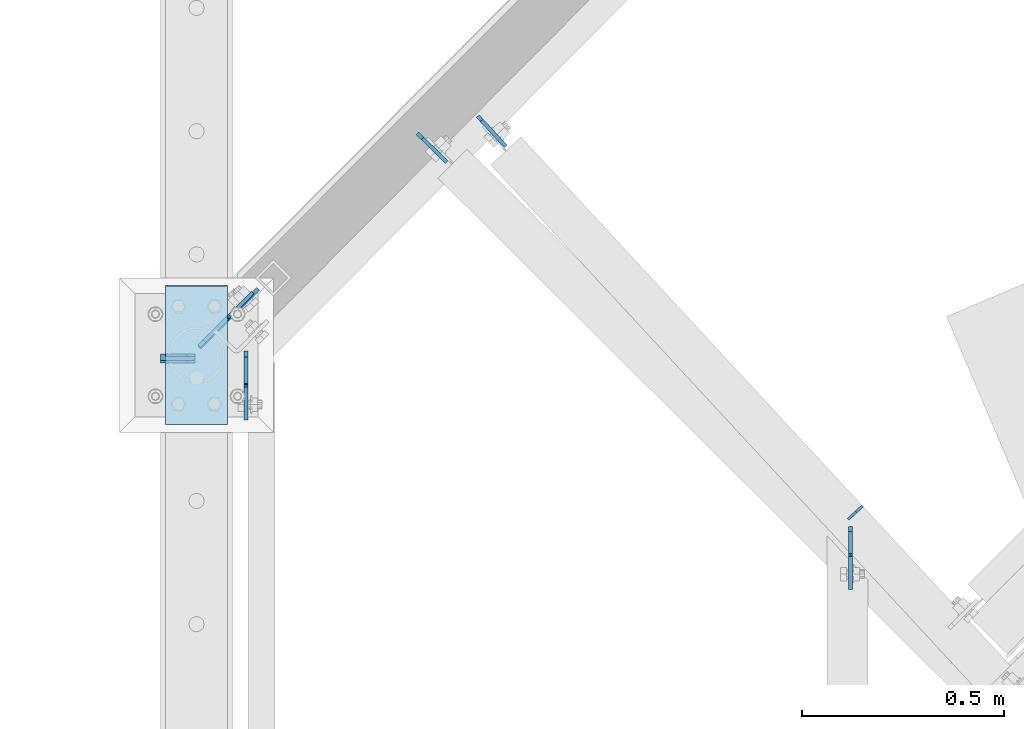
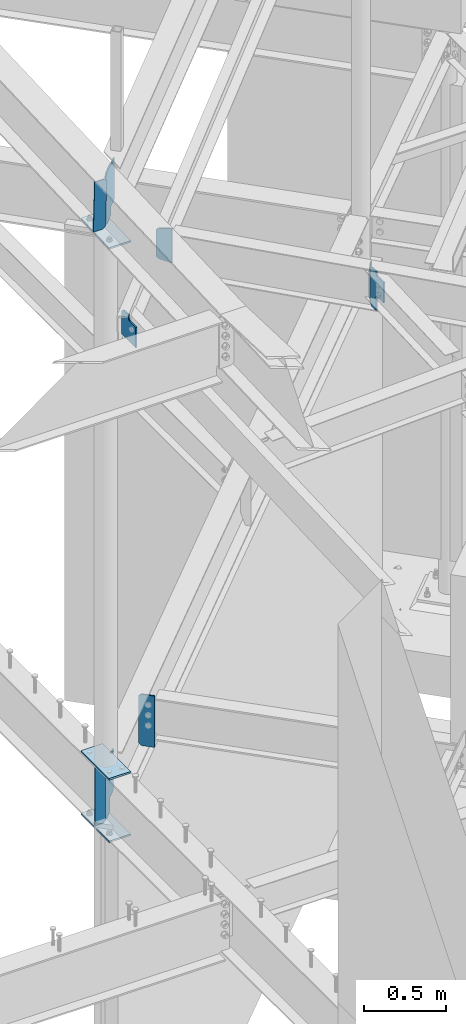
# One storey, part 915 of 975: 12 plates.
"""IFC2X3 building model written with IfcOpenShell, lengths in millimetres."""

import ifcopenshell
import ifcopenshell.guid

model = None  # the IFC model being written
_history = None  # IfcOwnerHistory: only IFC2X3 demands one
_inside = {}  # id of a spatial element -> (the spatial element, [elements in it])
_under = {}  # id of a project, library or spatial element -> (it, [spatial elements below it])
_declared = {}  # id of a project -> (the project, [libraries it declares])
_typed = {}  # id of a type object -> (the type object, [elements of that type])
_made_of = {}  # id of a material, layer set ... -> (it, [elements and type objects made of it])


def new_model(schema):
    """Start an empty IFC model of exactly this schema.

    Asked for "IFC4X3", IfcOpenShell would pick the latest addendum, in which some entities
    have other attributes; the version numbers below select the first issue.
    IFC2X3 requires an IfcOwnerHistory on every rooted entity: one is made here for all.
    """
    global model, _history
    if schema == "IFC4X3":
        model = ifcopenshell.file(schema_version=(4, 3, 0, 0))
    else:
        model = ifcopenshell.file(schema=schema)
    _inside.clear()
    _under.clear()
    _declared.clear()
    _typed.clear()
    _made_of.clear()
    _history = None
    if model.schema == "IFC2X3":
        org = make("IfcOrganization", Name="unknown")
        user = make(
            "IfcPersonAndOrganization",
            ThePerson=make("IfcPerson", FamilyName="unknown"),
            TheOrganization=org,
        )
        app = make(
            "IfcApplication",
            ApplicationDeveloper=org,
            Version="unknown",
            ApplicationFullName="unknown",
            ApplicationIdentifier="unknown",
        )
        _history = make(
            "IfcOwnerHistory",
            OwningUser=user,
            OwningApplication=app,
            ChangeAction="ADDED",
            CreationDate=0,
        )
    return model


def make(cls, **values):
    """One entity of the class cls with the attributes given. An attribute that is None is left unset."""
    return model.create_entity(
        cls, **{name: value for name, value in values.items() if value is not None}
    )


def rooted(cls, **values):
    """An entity with a GlobalId (a new one), such as an element, a storey or a relation."""
    return make(cls, GlobalId=ifcopenshell.guid.new(), OwnerHistory=_history, **values)


def si_unit(unit_type, name, prefix=None):
    """IfcSIUnit, for example si_unit("LENGTHUNIT", "METRE", prefix="MILLI")."""
    return make("IfcSIUnit", UnitType=unit_type, Prefix=prefix, Name=name)


def assignment(units):
    """IfcUnitAssignment: the units of a project."""
    return None if units is None else make("IfcUnitAssignment", Units=units)


def point(xyz):
    """IfcCartesianPoint."""
    return None if xyz is None else make("IfcCartesianPoint", Coordinates=xyz)


def direction(xyz):
    """IfcDirection."""
    return None if xyz is None else make("IfcDirection", DirectionRatios=xyz)


def frame(location, z_axis=None, x_axis=None):
    """IfcAxis2Placement3D, a coordinate frame: its origin and axes. An axis left out is left unset."""
    return make(
        "IfcAxis2Placement3D",
        Location=point(location),
        Axis=direction(z_axis),
        RefDirection=direction(x_axis),
    )


def origin_with_axes():
    """The frame at (0, 0, 0) with the z axis (0, 0, 1) and the x axis (1, 0, 0) written out."""
    return frame((0.0, 0.0, 0.0), z_axis=(0.0, 0.0, 1.0), x_axis=(1.0, 0.0, 0.0))


def place(relative_to, where):
    """IfcLocalPlacement: puts the frame where relative to a parent placement (None: the world)."""
    return make(
        "IfcLocalPlacement", PlacementRelTo=relative_to, RelativePlacement=where
    )


def context(
    kind, dimensions, precision=None, world=None, true_north=None, identifier=None
):
    """IfcGeometricRepresentationContext, for example the 3D "Model" context."""
    return make(
        "IfcGeometricRepresentationContext",
        ContextIdentifier=identifier,
        ContextType=kind,
        CoordinateSpaceDimension=dimensions,
        Precision=precision,
        WorldCoordinateSystem=world,
        TrueNorth=true_north,
    )


def subcontext(parent, identifier, kind, view, scale=None):
    """IfcGeometricRepresentationSubContext, for example "Body" below "Model"."""
    return make(
        "IfcGeometricRepresentationSubContext",
        ContextIdentifier=identifier,
        ContextType=kind,
        ParentContext=parent,
        TargetScale=scale,
        TargetView=view,
    )


def project(units=None, contexts=None):
    """IfcProject with its units and contexts."""
    return rooted(
        "IfcProject",
        Name="project",
        RepresentationContexts=contexts,
        UnitsInContext=assignment(units),
    )


def spatial(cls, under=None, at=None, **own):
    """A site, building, storey or space (cls), placed at a placement, below another one or the project."""
    s = rooted(cls, ObjectPlacement=at, **own)
    if under is not None:
        _under.setdefault(under.id(), (under, []))[1].append(s)
    return s


def faces_of(points, faces, orient=None, outer=None):
    """IfcFace entities. A face is a list of loops; a loop is a list of indices into points, from 0.

    orient and outer hold one flag for each loop. By default every Orientation is true, the
    first loop of a face is its IfcFaceOuterBound and the others are IfcFaceBound.
    """
    made = []
    for i, loops in enumerate(faces):
        bounds = []
        for j, loop in enumerate(loops):
            is_outer = j == 0 if outer is None else outer[i][j]
            bounds.append(
                make(
                    "IfcFaceOuterBound" if is_outer else "IfcFaceBound",
                    Bound=make("IfcPolyLoop", Polygon=[points[k] for k in loop]),
                    Orientation=True if orient is None else orient[i][j],
                )
            )
        made.append(make("IfcFace", Bounds=bounds))
    return made


def faceted_brep(points, faces, orient=None, outer=None, voids=None):
    """IfcFacetedBrep: a solid bounded by flat faces; with voids (closed shells), ...WithVoids."""
    shared = [point(p) for p in points]
    hull = make("IfcClosedShell", CfsFaces=faces_of(shared, faces, orient, outer))
    if voids is None:
        return make("IfcFacetedBrep", Outer=hull)
    return make(
        "IfcFacetedBrepWithVoids",
        Outer=hull,
        Voids=[
            make(cls, CfsFaces=faces_of(shared, fs, o, b)) for cls, fs, o, b in voids
        ],
    )


def shape(context_of_items, identifier, shape_type, items):
    """IfcShapeRepresentation: the items that make up one representation, for example the "Body"."""
    return make(
        "IfcShapeRepresentation",
        ContextOfItems=context_of_items,
        RepresentationIdentifier=identifier,
        RepresentationType=shape_type,
        Items=items,
    )


def material(Name=None, Category=None):
    """IfcMaterial."""
    return make("IfcMaterial", Name=Name, Category=Category)


def made_of(thing, what):
    """Note that an element or type object is made of a material, layer set ...; save() writes the relation."""
    if what is not None:
        _made_of.setdefault(what.id(), (what, []))[1].append(thing)
    return thing


def type_object(cls, material=None, **own):
    """A type object (cls), such as IfcWallType, which elements share."""
    return made_of(rooted(cls, **own), material)


def element(
    cls,
    number,
    at=None,
    inside=None,
    cuts=None,
    type_object=None,
    material=None,
    context=None,
    identifier="Body",
    shape_type=None,
    held_by="IfcProductDefinitionShape",
    body=None,
    shapes=None,
    **own,
):
    """One element of the class cls, such as IfcWall. Its Tag is "e" and its number.

    at: its placement. inside: the storey or other place that contains it. cuts: it is an
    opening in that element (IfcRelVoidsElement). A single representation is given by context,
    identifier, shape_type and body (its items); several are given by shapes. held_by: the class
    of the entity that holds the representations. save() writes the other relations.
    """
    e = rooted(cls, Tag="e%d" % number, ObjectPlacement=at, **own)
    if body is not None:
        shapes = [shape(context, identifier, shape_type, body)]
    if shapes is not None:
        e.Representation = make(held_by, Representations=shapes)
    if inside is not None:
        _inside.setdefault(inside.id(), (inside, []))[1].append(e)
    if cuts is not None:
        rooted(
            "IfcRelVoidsElement", RelatingBuildingElement=cuts, RelatedOpeningElement=e
        )
    if type_object is not None:
        _typed.setdefault(type_object.id(), (type_object, []))[1].append(e)
    return made_of(e, material)


def aggregate(whole, parts):
    """IfcRelAggregates: a whole, such as a stair, and the parts it consists of."""
    return rooted("IfcRelAggregates", RelatingObject=whole, RelatedObjects=parts)


def save(model, path):
    """Write the relations noted so far, then the file.

    IfcRelAggregates (storeys below a building ...), IfcRelContainedInSpatialStructure (elements
    in a storey), IfcRelDefinesByType, IfcRelAssociatesMaterial and IfcRelDeclares: one each for
    every whole, place, type object, material and project.
    """
    for whole, parts in _under.values():
        aggregate(whole, parts)
    for where, things in _inside.values():
        rooted(
            "IfcRelContainedInSpatialStructure",
            RelatedElements=things,
            RelatingStructure=where,
        )
    for kind, things in _typed.values():
        rooted("IfcRelDefinesByType", RelatedObjects=things, RelatingType=kind)
    for what, things in _made_of.values():
        rooted("IfcRelAssociatesMaterial", RelatedObjects=things, RelatingMaterial=what)
    for by, libraries in _declared.values():
        rooted("IfcRelDeclares", RelatingContext=by, RelatedDefinitions=libraries)
    model.write(path)


model = new_model("IFC2X3")

# Units and contexts
model_context = context("Model", 3, precision=1e-05, world=origin_with_axes())
body_context = subcontext(model_context, "Body", "Model", "MODEL_VIEW")
ifc_project = project(units=[si_unit("LENGTHUNIT", "METRE", prefix="MILLI"), si_unit("AREAUNIT", "SQUARE_METRE"), si_unit("VOLUMEUNIT", "CUBIC_METRE"), si_unit("MASSUNIT", "GRAM", prefix="KILO"), si_unit("TIMEUNIT", "SECOND"), si_unit("PLANEANGLEUNIT", "RADIAN"), si_unit("SOLIDANGLEUNIT", "STERADIAN"), si_unit("THERMODYNAMICTEMPERATUREUNIT", "DEGREE_CELSIUS"), si_unit("LUMINOUSINTENSITYUNIT", "LUMEN")], contexts=[model_context])

# Site, building, storey
site_placement = place(None, origin_with_axes())
site = spatial("IfcSite", under=ifc_project, at=site_placement, CompositionType="ELEMENT")
building_placement = place(site_placement, origin_with_axes())
building = spatial("IfcBuilding", under=site, at=building_placement, Name="Undefined", CompositionType="ELEMENT")
storey_placement = place(building_placement, origin_with_axes())
storey = spatial("IfcBuildingStorey", under=building, at=storey_placement, Name="Undefined", CompositionType="ELEMENT", Elevation=0.0)

# Plates
ifc_material = material(Name="STEEL/A36")
plate_type_1 = type_object("IfcPlateType", PredefinedType="NOTDEFINED")
plate_1_placement = place(storey_placement, frame((29839.6453487716, 7390.2823653138, 3514.725), z_axis=(0.498659746960537, 0.501336669960325, 0.707106781267402), x_axis=(0.498659747074602, 0.501336670074949, -0.707106781105694)))
element("IfcPlate", 1, at=plate_1_placement, inside=storey, type_object=plate_type_1, material=ifc_material, Name="PLATE", context=body_context, shape_type="Brep", body=[
    faceted_brep([(0.0, -4.76250000000073, 0.0), (-278.387939453176, -4.76250000000073, 278.387939453169), (-278.387939453176, 4.76250000000073, 278.387939453169), (0.0, 4.76250000000073, 0.0), (-278.38793945321, -4.76250000000073, 303.083648681655), (-278.38793945321, 4.76250000000073, 303.083648681655), (-221.696075439293, -4.76250000028085, 359.775512695589), (-221.696075439297, 4.76249999971878, 359.775512695589), (-211.593292011852, -4.76250000026994, 349.672729268135), (-211.593292011856, 4.76249999972788, 349.672729268135), (-207.473115897639, -4.7625000002663, 346.919715514257), (-207.473115897639, 4.76249999973152, 346.919715514257), (-202.613036791854, -4.7625000002663, 345.952985445063), (-202.613036791854, 4.76249999973334, 345.952985445063), (-197.752957569421, -4.7625000002663, 346.919714927837), (-197.752957569421, 4.76249999973152, 346.919714927833), (-193.632781123022, -4.7625000002663, 349.672728184563), (-193.632781123026, 4.76249999973334, 349.672728184563), (-139.383041381667, -4.76250000028085, 403.922454834279), (-139.38304138167, 4.76249999971697, 403.922454834279), (76.1431121826809, -4.76250000008986, 188.39631652844), (76.1431121826809, 4.76249999990796, 188.396316528437), (21.8933673291485, -4.76250000007167, 134.146569220211), (21.8933673291485, 4.76249999992797, 134.146569220207), (19.1403535409154, -4.76250000007167, 130.026392735705), (19.1403535409117, 4.76249999992615, 130.026392735705), (18.1736237092518, -4.76250000006985, 125.166313249294), (18.1736237092518, 4.76249999992979, 125.166313249294), (19.1403536847083, -4.76250000006803, 120.306233791482), (19.1403536847083, 4.76249999992979, 120.306233791482), (21.8933675948501, -4.76250000006075, 116.186057388433), (21.8933675948465, 4.76249999993706, 116.186057388433), (81.3875656128021, -4.762500000008, 56.6918601990001), (81.3875656128021, 4.76249999999163, 56.6918601990001), (24.6957035064406, -4.76250000000073, -6.3664629124105e-11), (24.6957035064406, 4.76250000000073, -6.3664629124105e-11)], [[[0, 1, 2, 3]], [[1, 4, 5, 2]], [[4, 6, 7, 5]], [[6, 8, 9, 7]], [[8, 10, 11, 9]], [[10, 12, 13, 11]], [[12, 14, 15, 13]], [[14, 16, 17, 15]], [[16, 18, 19, 17]], [[18, 20, 21, 19]], [[20, 22, 23, 21]], [[22, 24, 25, 23]], [[24, 26, 27, 25]], [[26, 28, 29, 27]], [[28, 30, 31, 29]], [[30, 32, 33, 31]], [[32, 34, 35, 33]], [[34, 0, 3, 35]], [[5, 7, 9, 11, 13, 15, 17, 19, 21, 23, 25, 27, 29, 31, 33, 35, 3, 2]], [[34, 32, 30, 28, 26, 24, 22, 20, 18, 16, 14, 12, 10, 8, 6, 4, 1, 0]]]),
])
plate_type_2 = type_object("IfcPlateType", PredefinedType="NOTDEFINED")
plate_2_placement = place(storey_placement, frame((30527.7330050997, 7958.60273431183, 7079.45434685882), z_axis=(0.11332154056535, -0.122418983530457, 0.985987738724608), x_axis=(0.669794519248186, -0.723565562268103, -0.166817802061815)))
element("IfcPlate", 2, at=plate_2_placement, inside=storey, type_object=plate_type_2, material=ifc_material, Name="PLATE", context=body_context, shape_type="Brep", body=[
    faceted_brep([(-2.38340940804301, -4.76250000000437, 14.0873001935779), (-34.6790677039808, -4.76250000015716, 204.972941505546), (-34.6790677039917, 4.76249999983702, 204.972941505546), (-2.38340940805028, 4.76249999998981, 14.0873001935779), (-23.547938522157, -4.76250000015716, 223.695963202161), (-23.5479385221661, 4.76249999983702, 223.695963202161), (60.3293075560268, -4.7625000000553, 252.467315673743), (60.3293075560196, 4.76249999993524, 252.467315673743), (103.043876648071, -4.76249999985521, 7.09405867382884e-11), (103.043876648066, 4.76250000013897, 7.27595761418343e-11), (14.2875003814897, -4.76249999997526, 9.09494701772928e-12), (14.2875003814825, 4.76250000001892, 9.09494701772928e-12)], [[[0, 1, 2, 3]], [[1, 4, 5, 2]], [[4, 6, 7, 5]], [[6, 8, 9, 7]], [[8, 10, 11, 9]], [[10, 0, 3, 11]], [[5, 7, 9, 11, 3, 2]], [[10, 8, 6, 4, 1, 0]]]),
])
plate_3_placement = place(storey_placement, frame((30378.691345395, 7916.46434733023, 3546.475), z_axis=(0.0, 0.0, 1.0), x_axis=(0.709002820319978, -0.705205644318249, 0.0)))
element("IfcPlate", 3, at=plate_3_placement, inside=storey, type_object=plate_type_2, material=ifc_material, Name="PLATE", context=body_context, shape_type="Brep", body=[
    faceted_brep([(0.0, -4.76250000000073, 17.4624996185303), (-7.27595761418343e-12, -4.76249999998981, 363.53750038147), (0.0, 4.76249999999163, 363.53750038147), (0.0, 4.76250000000073, 17.4624996185303), (17.4624996185375, -4.76250000000618, 381.0), (17.4624996185448, 4.7624999999789, 381.0), (101.599998474208, -4.76250000006803, 381.0), (101.599998474216, 4.76249999991705, 381.0), (101.600006103516, -4.76250000000073, 0.0), (101.600006103516, 4.76250000000073, 0.0), (17.4624996185303, -4.76250000000073, 0.0), (17.4624996185303, 4.76250000000073, 0.0)], [[[0, 1, 2, 3]], [[1, 4, 5, 2]], [[4, 6, 7, 5]], [[6, 8, 9, 7]], [[8, 10, 11, 9]], [[10, 0, 3, 11]], [[5, 7, 9, 11, 3, 2]], [[10, 8, 6, 4, 1, 0]]]),
])
plate_type_3 = type_object("IfcPlateType", PredefinedType="NOTDEFINED")
plate_4_placement = place(storey_placement, frame((31443.7736286057, 6962.01096089022, 7308.85), z_axis=(0.0, 0.0, -1.0), x_axis=(0.733848438057782, 0.679313234053447, 0.0)))
element("IfcPlate", 4, at=plate_4_placement, inside=storey, type_object=plate_type_3, material=ifc_material, Name="PLATE", context=body_context, shape_type="Brep", body=[
    faceted_brep([(3.63797880709171e-12, -3.17499999999927, 57.1500015258789), (3.63797880709171e-12, -3.17499999999927, 231.77498626709), (3.63797880709171e-12, 3.17500000000291, 231.77498626709), (3.63797880709171e-12, 3.17500000000291, 57.1500015258789), (26.9874992370314, -3.17500000002838, 288.924987792969), (26.9874992370278, 3.17499999997017, 288.924987792969), (48.4187507628849, -3.17500000005566, 288.924987792969), (48.4187507628849, 3.17499999994834, 288.924987792969), (48.4187507628849, -3.17500000005566, 0.0), (48.4187507628849, 3.17499999994834, 0.0), (26.9874992370314, -3.17500000002838, 0.0), (26.9874992370278, 3.17499999997017, 0.0)], [[[0, 1, 2, 3]], [[1, 4, 5, 2]], [[4, 6, 7, 5]], [[6, 8, 9, 7]], [[8, 10, 11, 9]], [[10, 0, 3, 11]], [[5, 7, 9, 11, 3, 2]], [[10, 8, 6, 4, 1, 0]]]),
])
plate_type_4 = type_object("IfcPlateType", PredefinedType="NOTDEFINED")
plate_5_placement = place(storey_placement, frame((31449.1690766088, 6944.02677710158, 7032.6249999973), z_axis=(0.0, -0.707106781186557, 0.707106781186538), x_axis=(0.0, -0.707106781186538, -0.707106781186557)))
element("IfcPlate", 5, at=plate_5_placement, inside=storey, type_object=plate_type_4, material=ifc_material, Name="PLATE", context=body_context, shape_type="Brep", body=[
    faceted_brep([(0.0, -4.76250000000073, 0.0), (-186.34031677249, -4.76250000001892, 186.340316772493), (-186.340316772494, 4.76249999998254, 186.340316772492), (0.0, 4.76250000000073, 0.0), (-186.34031677249, -4.76250000001164, 204.300827026403), (-186.340316772494, 4.76249999998981, 204.300827026401), (-148.558761596702, -4.76249999996435, 242.082382202191), (-148.558761596705, 4.76250000003347, 242.082382202189), (-139.736022728899, -4.76249999996799, 233.259650896279), (-139.736022728903, 4.76250000003347, 233.259650896277), (-135.615846690651, -4.76249999996799, 230.506639428243), (-135.615846690653, 4.76250000003347, 230.50663942824), (-130.755768633268, -4.76249999996435, 229.539910921663), (-130.755768633269, 4.76250000003711, 229.53991092166), (-125.895690873953, -4.76249999996071, 230.506640926742), (-125.895690873956, 4.76250000004075, 230.50664092674), (-121.775515684534, -4.76249999995707, 233.259653665143), (-121.775515684538, 4.76250000004438, 233.259653665141), (-67.2925720214935, -4.76249999989523, 287.742584228564), (-67.2925720214953, 4.76250000010259, 287.742584228563), (40.4705047607513, -4.76249999988431, 179.979522705109), (40.4705047607495, 4.7625000001135, 179.979522705107), (-14.0124385462914, -4.76249999994616, 125.496582672972), (-14.012438546295, 4.7625000000553, 125.49658267297), (-16.7654525776834, -4.7624999999498, 121.376406270457), (-16.7654525776852, 4.76250000005166, 121.376406270456), (-17.7321826392545, -4.76249999995343, 116.516326761549), (-17.7321826392581, 4.76250000004802, 116.516326761547), (-16.765452841486, -4.76249999995707, 111.656247200167), (-16.7654528414878, 4.76250000004438, 111.656247200164), (-14.0124390337369, -4.76249999995343, 107.536070648221), (-14.0124390337369, 4.76250000004802, 107.536070648219), (55.7420692443957, -4.7624999999498, 37.7815589904855), (55.742069244392, 4.76250000005166, 37.7815589904837), (17.9605121612585, -4.76249999999345, 8.81783535078284e-12), (17.9605121612549, 4.762500000008, 6.08935124546406e-12)], [[[0, 1, 2, 3]], [[1, 4, 5, 2]], [[4, 6, 7, 5]], [[6, 8, 9, 7]], [[8, 10, 11, 9]], [[10, 12, 13, 11]], [[12, 14, 15, 13]], [[14, 16, 17, 15]], [[16, 18, 19, 17]], [[18, 20, 21, 19]], [[20, 22, 23, 21]], [[22, 24, 25, 23]], [[24, 26, 27, 25]], [[26, 28, 29, 27]], [[28, 30, 31, 29]], [[30, 32, 33, 31]], [[32, 34, 35, 33]], [[34, 0, 3, 35]], [[5, 7, 9, 11, 13, 15, 17, 19, 21, 23, 25, 27, 29, 31, 33, 35, 3, 2]], [[34, 32, 30, 28, 26, 24, 22, 20, 18, 16, 14, 12, 10, 8, 6, 4, 1, 0]]]),
])
plate_type_5 = type_object("IfcPlateType", PredefinedType="NOTDEFINED")
plate_6_placement = place(storey_placement, frame((29743.4, 7351.29395752706, 8283.22357245661), z_axis=(0.0, 0.0415532340156014, -0.999136291375128), x_axis=(1.0, 0.0, 0.0)))
element("IfcPlate", 6, at=plate_6_placement, inside=storey, type_object=plate_type_5, material=ifc_material, Name="PLATE", context=body_context, shape_type="Brep", body=[
    faceted_brep([(0.0, -3.17499999999927, 0.0), (1.83717929758132e-10, -3.17499999972279, 381.000000000335), (1.90993887372315e-10, 3.17500000029031, 381.000000000333), (0.0, 3.17499999999927, 0.0), (65.8812522888184, -3.17500000005202, 381.000000000021), (65.8812522888184, 3.17499999994834, 381.000000000021), (84.9312515258789, -3.1750000000502, 361.950000762959), (84.9312515258789, 3.17499999995107, 361.950000762959), (84.9312515258789, -3.17500000000382, 19.0499992370596), (84.9312515258789, 3.17499999999563, 19.0499992370624), (65.8812522888184, -3.17500000000109, -1.81898940354586e-12), (65.8812522888184, 3.17499999999836, 9.09494701772928e-13)], [[[0, 1, 2, 3]], [[1, 4, 5, 2]], [[4, 6, 7, 5]], [[6, 8, 9, 7]], [[8, 10, 11, 9]], [[10, 0, 3, 11]], [[5, 7, 9, 11, 3, 2]], [[10, 8, 6, 4, 1, 0]]]),
])
plate_type_6 = type_object("IfcPlateType", PredefinedType="NOTDEFINED")
plate_7_placement = place(storey_placement, frame((29756.1, 7367.5875, 3925.8875), z_axis=(0.0, 0.0, -1.0), x_axis=(1.0, 0.0, 0.0)))
element("IfcPlate", 7, at=plate_7_placement, inside=storey, type_object=plate_type_6, material=ifc_material, Name="PLATE", context=body_context, shape_type="Brep", body=[
    faceted_brep([(0.0, -3.17499999999927, 0.0), (0.0, -3.17499999999927, 428.625), (0.0, 3.17499999999927, 428.625), (0.0, 3.17499999999927, 0.0), (53.1812477111816, -3.17499999999927, 428.625), (53.1812477111816, 3.17499999999927, 428.625), (72.2312469482422, -3.17499999999927, 409.575000762939), (72.2312469482422, 3.17499999999927, 409.575000762939), (72.2312469482422, -3.17499999999927, 19.0499992370605), (72.2312469482422, 3.17499999999927, 19.0499992370605), (53.1812477111816, -3.17499999999927, 0.0), (53.1812477111816, 3.17499999999927, 0.0)], [[[0, 1, 2, 3]], [[1, 4, 5, 2]], [[4, 6, 7, 5]], [[6, 8, 9, 7]], [[8, 10, 11, 9]], [[10, 0, 3, 11]], [[5, 7, 9, 11, 3, 2]], [[10, 8, 6, 4, 1, 0]]]),
])
plate_type_7 = type_object("IfcPlateType", PredefinedType="NOTDEFINED")
plate_8_placement = place(storey_placement, frame((29839.6469329481, 7386.24167923894, 7921.60630951221), z_axis=(0.498423163773252, 0.501571878771822, 0.707106781355947), x_axis=(0.498423164012041, 0.501571879012163, -0.707106781017149)))
element("IfcPlate", 8, at=plate_8_placement, inside=storey, type_object=plate_type_7, material=ifc_material, Name="PLATE", context=body_context, shape_type="Brep", body=[
    faceted_brep([(0.0, -4.76250000000073, 0.0), (-244.547485351733, -4.76249999973152, 244.547485351472), (-244.547485351733, 4.76250000026994, 244.547485351472), (0.0, 4.76250000000073, 0.0), (-244.547485351752, -4.76249999970787, 269.243194579973), (-244.547485351752, 4.76250000029177, 269.243194579965), (-177.50001525902, -4.76249999964421, 340.366760253706), (-177.500015259024, 4.76250000035725, 340.366760253706), (-174.928615263132, -4.76249999964784, 337.942725920304), (-174.928615263132, 4.76250000035179, 337.942725920304), (-170.969705305695, -4.76249999965148, 335.445088447421), (-170.969705305695, 4.76250000034997, 335.445088447417), (-166.361621045135, -4.76249999964784, 334.622458248217), (-166.361621045135, 4.76250000034634, 334.622458248217), (-161.78304131034, -4.76249999965148, 335.595992330393), (-161.78304131034, 4.76250000034997, 335.595992330393), (-157.908299502493, -4.76249999964602, 338.222308556502), (-157.908299502493, 4.76250000034997, 338.222308556502), (-103.205718994404, -4.76249999960055, 393.293548583708), (-103.205718994404, 4.76250000039727, 393.293548583708), (112.320426940805, -4.76249999984066, 177.76741027812), (112.320426940805, 4.7625000001608, 177.76741027812), (56.8825765342281, -4.76249999988795, 121.884664656838), (56.8825765342281, 4.7625000001135, 121.884664656835), (54.1156115917383, -4.76249999989159, 117.678512328603), (54.1156115917383, 4.76250000010623, 117.678512328603), (53.200430788871, -4.76249999989523, 112.727728905818), (53.200430788871, 4.76250000010259, 112.727728905815), (54.2808609716776, -4.7624999999025, 107.810363450477), (54.2808609716776, 4.76250000009895, 107.810363450477), (57.1871052376373, -4.76249999990432, 103.699213165226), (57.1871052376409, 4.76250000009532, 103.699213165226), (91.7431640624563, -4.76249999993888, 71.1235656737263), (91.74316406246, 4.76250000006075, 71.1235656737263), (24.6957035064406, -4.76250000000073, -6.3664629124105e-11), (24.6957035064406, 4.76250000000073, -6.3664629124105e-11)], [[[0, 1, 2, 3]], [[1, 4, 5, 2]], [[4, 6, 7, 5]], [[6, 8, 9, 7]], [[8, 10, 11, 9]], [[10, 12, 13, 11]], [[12, 14, 15, 13]], [[14, 16, 17, 15]], [[16, 18, 19, 17]], [[18, 20, 21, 19]], [[20, 22, 23, 21]], [[22, 24, 25, 23]], [[24, 26, 27, 25]], [[26, 28, 29, 27]], [[28, 30, 31, 29]], [[30, 32, 33, 31]], [[32, 34, 35, 33]], [[34, 0, 3, 35]], [[5, 7, 9, 11, 13, 15, 17, 19, 21, 23, 25, 27, 29, 31, 33, 35, 3, 2]], [[34, 32, 30, 28, 26, 24, 22, 20, 18, 16, 14, 12, 10, 8, 6, 4, 1, 0]]]),
])
plate_type_8 = type_object("IfcPlateType", PredefinedType="NOTDEFINED")
plate_9_placement = place(storey_placement, frame((29954.5369999449, 7377.70063276053, 7241.20685877553), z_axis=(0.0, -1.0, 0.0), x_axis=(0.0, 0.0, -1.0)))
element("IfcPlate", 9, at=plate_9_placement, inside=storey, type_object=plate_type_8, material=ifc_material, Name="PLATE", context=body_context, shape_type="Brep", body=[
    faceted_brep([(0.0, -4.76250000000073, 0.0), (-14.2875003814697, -4.76250000001164, 14.2875003814715), (-14.2875003814697, 4.76249999998981, 14.2875003814697), (0.0, 4.76250000000073, 0.0), (-19.2664604187012, -4.7625000000553, 79.7871704101581), (-19.2664604187012, 4.76249999994616, 79.7871704101562), (7.74125480651855, -4.7625000000553, 79.7871704101581), (7.74125480651855, 4.76249999994616, 79.7871704101562), (13.2088444924166, -4.7625000000553, 80.8747416184415), (13.2088444924166, 4.76249999994616, 80.8747416184387), (17.8440432124607, -4.7625000000553, 83.9718823856856), (17.8440432124607, 4.76249999994616, 83.9718823856829), (20.9411839797058, -4.76250000005894, 88.6070811057298), (20.9411839797058, 4.76249999994252, 88.607081105727), (22.0287551879883, -4.76250000005894, 94.0746707916278), (22.0287551879883, 4.76249999993888, 94.074670791626), (22.0287551879883, -4.76250000010987, 170.214492797853), (22.0287551879883, 4.76249999989159, 170.214492797852), (174.428756713867, -4.76250000010987, 170.214492797853), (174.428756713867, 4.76249999989159, 170.214492797852), (174.428756713867, -4.76250000000437, 1.81898940354586e-12), (174.428756713867, 4.76249999999709, 0.0)], [[[0, 1, 2, 3]], [[1, 4, 5, 2]], [[4, 6, 7, 5]], [[6, 8, 9, 7]], [[8, 10, 11, 9]], [[10, 12, 13, 11]], [[12, 14, 15, 13]], [[14, 16, 17, 15]], [[16, 18, 19, 17]], [[18, 20, 21, 19]], [[20, 0, 3, 21]], [[5, 7, 9, 11, 13, 15, 17, 19, 21, 3, 2]], [[20, 18, 16, 14, 12, 10, 8, 6, 4, 1, 0]]]),
])
plate_type_9 = type_object("IfcPlateType", PredefinedType="NOTDEFINED")
for number, where, z_axis, x_axis, name in (
    (10, (29908.5, 7196.54944587973, 7877.98092598293), (0.0, 0.999136291375128, 0.0415532340156014), (-0.999999999999998, 6.90000001668524e-08, 0.0), "PLATE"),
    (11, (29756.1, 7196.1375, 3943.35), (0.0, 1.0, 0.0), (1.0, 0.0, 0.0), "PLATE"),
    (12, (29908.5, 7196.1375, 3479.8), (0.0, 1.0, 0.0), (-0.999999999999998, 6.90000001668524e-08, 0.0), "PLATE"),
):
    element("IfcPlate", number, at=place(storey_placement, frame(where, z_axis=z_axis, x_axis=x_axis)), inside=storey, type_object=plate_type_9, material=ifc_material, Name=name, context=body_context, shape_type="Brep", body=[
        faceted_brep([(0.0, -6.34999999998763, -3.63797880709171e-12), (-4.32919478043914e-10, -6.34999999999991, 342.899993895661), (-4.32919478043914e-10, 6.34999999999991, 342.899993895661), (0.0, 6.34999999999491, 5.45696821063757e-12), (152.399993896484, -6.34999999995307, 342.899993896505), (152.399993896484, 6.35000000004766, 342.899993896504), (152.399993896484, -6.34999999999854, 9.09494701772928e-13), (152.399993896484, 6.35000000000127, 0.0)], [[[0, 1, 2, 3]], [[1, 4, 5, 2]], [[4, 6, 7, 5]], [[6, 0, 3, 7]], [[5, 7, 3, 2]], [[6, 4, 1, 0]]]),
    ])

save(model, "model.ifc")
